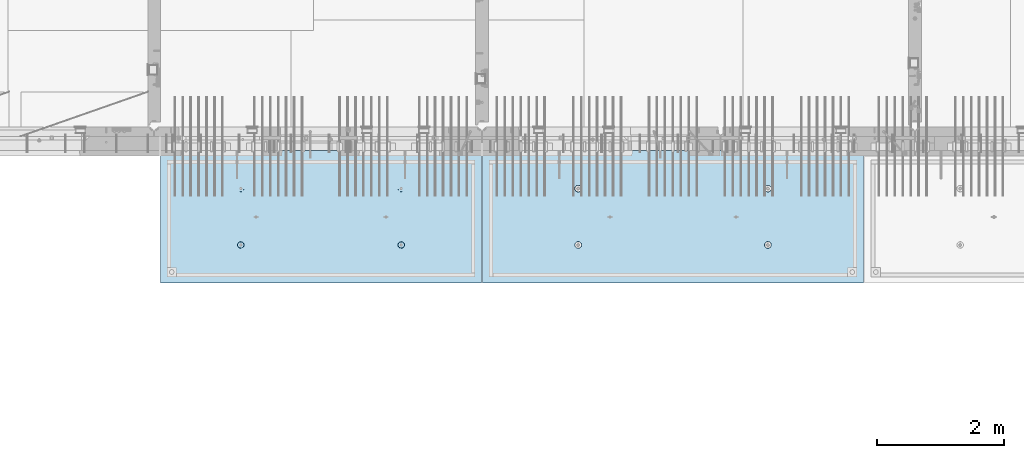
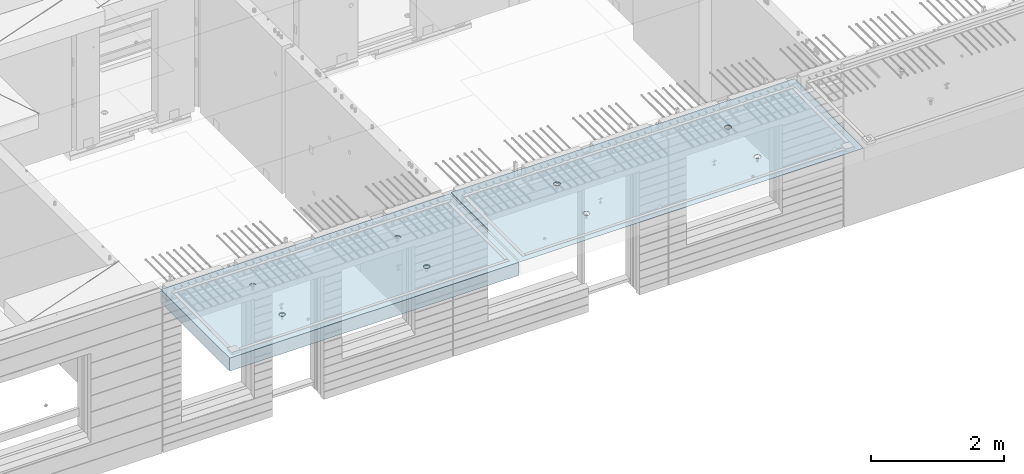
# One storey, part 200 of 352: 2 slabs, 2 elements without a shape of their own.
"""IFC2X3 building model written with IfcOpenShell, lengths in millimetres."""

from ifc_helpers import new_model, si_unit, frame, origin_with_axes, place, context, subcontext, project, spatial, faceted_brep, material, type_object, element, aggregate, save


model = new_model("IFC2X3")

# Units and contexts
model_context = context("Model", 3, precision=1e-05, world=origin_with_axes())
body_context = subcontext(model_context, "Body", "Model", "MODEL_VIEW")
ifc_project = project(units=[si_unit("LENGTHUNIT", "METRE", prefix="MILLI"), si_unit("AREAUNIT", "SQUARE_METRE"), si_unit("VOLUMEUNIT", "CUBIC_METRE"), si_unit("MASSUNIT", "GRAM", prefix="KILO"), si_unit("TIMEUNIT", "SECOND"), si_unit("PLANEANGLEUNIT", "RADIAN"), si_unit("SOLIDANGLEUNIT", "STERADIAN"), si_unit("THERMODYNAMICTEMPERATUREUNIT", "DEGREE_CELSIUS"), si_unit("LUMINOUSINTENSITYUNIT", "LUMEN")], contexts=[model_context])

# Site, building, storey
site_placement = place(None, origin_with_axes())
site = spatial("IfcSite", under=ifc_project, at=site_placement, CompositionType="ELEMENT")
building_placement = place(site_placement, origin_with_axes())
building = spatial("IfcBuilding", under=site, at=building_placement, CompositionType="ELEMENT")
storey_placement = place(building_placement, origin_with_axes())
storey = spatial("IfcBuildingStorey", under=building, at=storey_placement, Name="6", CompositionType="ELEMENT", Elevation=0.0)

# Assembly, slab
assembly_1_placement = place(storey_placement, origin_with_axes())
assembly_1 = element("IfcElementAssembly", 1, at=assembly_1_placement, inside=storey, AssemblyPlace="NOTDEFINED", PredefinedType="REINFORCEMENT_UNIT")
ifc_material = material(Name="CONCRETE/C35/45")
slab_type_1 = type_object("IfcSlabType", PredefinedType="NOTDEFINED")
slab_1_placement = place(assembly_1_placement, frame((27799.9998568133, 7629.99655735226, 99720.0), z_axis=(-1.11800000013248e-06, -0.999999999999375, 0.0), x_axis=(-0.999999999999093, 1.34699999998405e-06, 0.0)))
slab_1 = element("IfcSlab", 2, at=slab_1_placement, type_object=slab_type_1, material=ifc_material, PredefinedType="FLOOR", context=body_context, shape_type="Brep", body=[
    faceted_brep([(4430.38332613536, -4.08995228011918, 616.123557002266), (4431.90609271965, 10.0, 615.628782084005), (4439.08875686405, 10.0, 629.725594302773), (4437.8062304225, -3.95053914321761, 630.657402050439), (4450.27603094506, 10.0, 640.912894136913), (4449.35160622641, -3.83996043598745, 642.185252526786), (4464.3728266293, 10.0, 648.095590732159), (4463.88931892896, -3.76899254079035, 649.583668593681), (4479.99925133704, 10.0, 650.570591700976), (4479.99924953932, -3.74454363348195, 652.132471659324), (4495.6256817422, 10.0, 648.095626704194), (4496.1091860045, -3.76899218543258, 649.583705640341), (4509.72249396096, 10.0, 640.912962559792), (4510.64691570547, -3.83995975981816, 642.185323015524), (4520.9097937951, 10.0, 629.725688478787), (4522.19231800603, -3.95053821212787, 630.657499116635), (4528.09249039035, 10.0, 615.628892794549), (4529.6152557173, -4.08995118488383, 616.123671179757), (4530.56749135917, 10.0, 600.002468086805), (4532.18619485158, -4.24459073322942, 600.002469949934), (4528.09252636238, 10.0, 584.37603768165), (4529.64872932557, -4.39933455047139, 583.870398667863), (4520.90986221798, 10.0, 570.279225462882), (4522.24649000407, -4.53902051890327, 569.308110882728), (4509.72258813697, 10.0, 559.091925628744), (4510.70111430095, -4.6499364652409, 557.745103167879), (4495.62579245274, 10.0, 551.909229033497), (4496.142736776, -4.72117719323433, 550.318244231095), (4479.99936774499, 10.0, 549.43422806468), (4479.99936967367, -4.74573031402542, 547.758576892632), (4464.37293733984, 10.0, 551.909193061462), (4463.8559966665, -4.72117755009094, 550.318207030491), (4450.27612512107, 10.0, 559.091857205865), (4449.29760201216, -4.64993714379671, 557.745032430054), (4439.08882528693, 10.0, 570.279131286869), (4437.75219965053, -4.53902145239408, 569.308013567449), (4431.90612869169, 10.0, 584.375926971106), (4430.34992677396, -4.39933564719104, 583.87028433643), (4429.43112772287, 10.0, 600.002351678851), (4427.81242409951, -4.24459188559558, 600.002349815723), (0.0, 10.0, 0.0), (0.0, -10.0, 0.0), (0.000819232023786753, 10.0, 2085.00366210937), (5980.0, 10.0, -2.4019755073823e-09), (5980.0, -10.0, -2.4019755073823e-09), (5980.0009765625, 10.0, 2085.00366210937), (1450.3499233011, -4.39936856077111, 583.866853138679), (1451.90612877595, 10.0, 584.37249692914), (1449.43112780714, 10.0, 599.998921636884), (1447.81242044485, -4.24462478808709, 599.998919773752), (1457.75219670802, -4.53905437597132, 569.304581326389), (1459.0888253712, 10.0, 570.275701244902), (1469.29759989681, -4.64997007531929, 557.741599360567), (1470.27612520534, 10.0, 559.088427163899), (1483.85599559418, -4.7212104867067, 550.31477342891), (1484.3729374241, 10.0, 551.905763019495), (1499.99936975794, -4.74576325241651, 547.755143107666), (1499.99936782926, 10.0, 549.430798022713), (1516.14273801685, -4.72121012986463, 550.314810629518), (1515.62579253701, 10.0, 551.905798991532), (1530.70111658485, -4.64996939677803, 557.741670098397), (1529.72258822124, 10.0, 559.088495586778), (1542.24649311513, -4.53905344249506, 569.304678641675), (1540.90986230225, 10.0, 570.275795420916), (1549.64873296696, -4.39936746405147, 583.866967470121), (1548.09252644665, 10.0, 584.372607639683), (1552.18619867476, -4.24462363570638, 599.999039907971), (1550.56749144343, 10.0, 599.999038044839), (1549.61525935629, -4.08998407628678, 616.120242292795), (1548.09249047462, 10.0, 615.625462752582), (1542.19232111321, -3.95057109353365, 630.654071270945), (1540.90979387937, 10.0, 629.72225843682), (1530.64691798548, -3.83999263332225, 642.181895995745), (1529.72249404523, 10.0, 640.909532517825), (1516.10918724295, -3.76902505384351, 649.580279150618), (1515.62568182647, 10.0, 648.092196662228), (1499.99924962358, -3.7445765001321, 652.129045352205), (1499.9992514213, 10.0, 650.56716165901), (1483.88931785903, -3.76902540921583, 649.580242103954), (1484.37282671356, 10.0, 648.092160690191), (1469.35160411493, -3.83999330949155, 642.181825507), (1470.27603102933, 10.0, 640.909464094946), (1457.80622748385, -3.9505720246525, 630.653974204743), (1459.08875694832, 10.0, 629.722164260806), (1450.3833226649, -4.08998517153668, 616.120128115297), (1451.90609280392, 10.0, 615.625352042039), (1450.18528173966, 4.08930273250735, 1468.81238974452), (1450.82407776805, 10.0, 1469.01994796889), (1448.29345879993, 10.0, 1484.99752828805), (1447.63943102495, 4.24455558012414, 1484.99752753526), (1457.61190709188, 3.94915737991687, 1454.20221107617), (1458.16818327555, 10.0, 1454.60637035917), (1469.19529226424, 3.83787679090165, 1442.60118929624), (1469.60688310596, 10.0, 1443.16769686061), (1483.80158206606, 3.76640201332339, 1435.14993064656), (1484.02047762178, 10.0, 1435.82362453319), (1499.99806458492, 3.74176847410854, 1432.58187967207), (1499.99806376637, 10.0, 1433.29304234547), (1516.19454117951, 3.76640237134416, 1435.14996796955), (1515.97564408552, 10.0, 1435.82366131359), (1530.80081379559, 3.8378774716839, 1442.60126026678), (1530.38922169525, 10.0, 1443.16776682109), (1542.38417222175, 3.94915831647813, 1454.2023087116), (1541.82789519381, 10.0, 1454.6064666515), (1549.8107639085, 4.08930383282132, 1468.81250445209), (1549.17196752123, 10.0, 1469.02006116732), (1552.35657735256, 4.24455673628836, 1484.9976480647), (1551.70254970896, 10.0, 1484.99764731191), (1549.77718017658, 4.39970502781216, 1501.17188586406), (1549.17193074083, 10.0, 1500.97522763107), (1542.32982200517, 4.53957665037888, 1515.75352812725), (1541.82782523334, 10.0, 1515.38880524079), (1530.74643689407, 4.65051889081951, 1527.31927700612), (1530.38912540293, 10.0, 1526.82747873935), (1516.16088003051, 4.72171993891243, 1534.74199930817), (1515.9755308871, 10.0, 1534.17155106677), (1499.99794405534, 4.74624892331485, 1537.2991504223), (1499.99794474251, 10.0, 1536.70213325449), (1483.83501395426, 4.72171958237595, 1534.74196213963), (1484.02036442336, 10.0, 1534.17151428637), (1469.24947414505, 4.65051821242378, 1527.31920628548), (1469.60678681363, 10.0, 1526.82740877888), (1457.66611561777, 4.53957571620413, 1515.75343074172), (1458.16811331507, 10.0, 1515.38870894846), (1450.21879098044, 4.39970392896794, 1501.17177131094), (1450.82404098765, 10.0, 1500.97511443265), (4495.97553080284, 10.0, 1534.17498110874), (4496.16087879206, 4.72175280732336, 1534.74542579789), (4479.99794397108, 4.746281789965, 1537.30257672942), (4479.99794465824, 10.0, 1536.70556329646), (4510.38912531866, 10.0, 1526.83090878132), (4510.74643461406, 4.65055176430906, 1527.3227040259), (4521.82782514907, 10.0, 1515.39223528276), (4522.32981889799, 4.53960953179921, 1515.75695597294), (4529.17193065656, 10.0, 1500.97865767303), (4529.77717653759, 4.39973791921511, 1501.17531475103), (4531.70254962468, 10.0, 1485.00107735388), (4532.35657352936, 4.24458963877987, 1485.00107810666), (4529.17196743696, 10.0, 1469.02349120928), (4529.8107602671, 4.08933674640139, 1468.81593564983), (4521.82789510954, 10.0, 1454.60989669347), (4522.38416911069, 3.94919124005537, 1454.20574095265), (4510.38922161098, 10.0, 1443.17119686305), (4510.8008115117, 3.83791040322103, 1442.60469333626), (4495.97564400126, 10.0, 1435.82709135556), (4496.19453993865, 3.76643530797446, 1435.15340157113), (4479.99806368211, 10.0, 1433.29647238744), (4479.99806450065, 3.74180141248507, 1432.58531345704), (4464.02047753751, 10.0, 1435.82705457516), (4463.80158313838, 3.76643494995369, 1435.15336424814), (4449.60688302169, 10.0, 1443.17112690258), (4449.19529437959, 3.83790972242423, 1442.60462236572), (4438.16818319128, 10.0, 1454.60980040114), (4437.61191003439, 3.94919030349411, 1454.20564331723), (4430.82407768378, 10.0, 1469.02337801086), (4430.18528521251, 4.08933564607287, 1468.81582094227), (4437.66611855642, 4.53960859763902, 1515.75685858742), (4449.24947625653, 4.65055108592787, 1527.32263330526), (4463.83501502419, 4.72175245078688, 1534.74538862936), (4427.63943467959, 4.24458848261565, 1485.00095757723), (4430.2187944509, 4.39973682038544, 1501.17520019791), (4464.02036433909, 10.0, 1534.17494432834), (4449.60678672936, 10.0, 1526.83083882084), (4438.1681132308, 10.0, 1515.39213899043), (4430.82404090338, 10.0, 1500.97854447461), (4428.29345871566, 10.0, 1485.00095833002)], [[[0, 1, 2, 3]], [[3, 2, 4, 5]], [[5, 4, 6, 7]], [[7, 6, 8, 9]], [[10, 11, 9, 8]], [[12, 13, 11, 10]], [[14, 15, 13, 12]], [[16, 17, 15, 14]], [[18, 19, 17, 16]], [[20, 21, 19, 18]], [[22, 23, 21, 20]], [[24, 25, 23, 22]], [[26, 27, 25, 24]], [[27, 26, 28, 29]], [[29, 28, 30, 31]], [[31, 30, 32, 33]], [[33, 32, 34, 35]], [[35, 34, 36, 37]], [[37, 36, 38, 39]], [[39, 38, 1, 0]], [[40, 41, 42]], [[40, 43, 44, 41]], [[43, 45, 44]], [[46, 47, 48, 49]], [[50, 51, 47, 46]], [[52, 53, 51, 50]], [[54, 55, 53, 52]], [[56, 57, 55, 54]], [[58, 59, 57, 56]], [[59, 58, 60, 61]], [[61, 60, 62, 63]], [[63, 62, 64, 65]], [[65, 64, 66, 67]], [[67, 66, 68, 69]], [[69, 68, 70, 71]], [[71, 70, 72, 73]], [[73, 72, 74, 75]], [[75, 74, 76, 77]], [[78, 79, 77, 76]], [[80, 81, 79, 78]], [[82, 83, 81, 80]], [[84, 85, 83, 82]], [[49, 48, 85, 84]], [[86, 87, 88, 89]], [[90, 91, 87, 86]], [[92, 93, 91, 90]], [[94, 95, 93, 92]], [[96, 97, 95, 94]], [[98, 99, 97, 96]], [[100, 101, 99, 98]], [[101, 100, 102, 103]], [[103, 102, 104, 105]], [[105, 104, 106, 107]], [[107, 106, 108, 109]], [[109, 108, 110, 111]], [[111, 110, 112, 113]], [[113, 112, 114, 115]], [[115, 114, 116, 117]], [[117, 116, 118, 119]], [[120, 121, 119, 118]], [[122, 123, 121, 120]], [[124, 125, 123, 122]], [[89, 88, 125, 124]], [[126, 127, 128, 129]], [[130, 131, 127, 126]], [[132, 133, 131, 130]], [[134, 135, 133, 132]], [[136, 137, 135, 134]], [[138, 139, 137, 136]], [[140, 141, 139, 138]], [[142, 143, 141, 140]], [[143, 142, 144, 145]], [[145, 144, 146, 147]], [[147, 146, 148, 149]], [[149, 148, 150, 151]], [[151, 150, 152, 153]], [[153, 152, 154, 155]], [[41, 44, 45, 42], [3, 5, 7, 9, 11, 13, 15, 17, 19, 21, 23, 25, 27, 29, 31, 33, 35, 37, 39, 0], [156, 157, 158, 128, 127, 131, 133, 135, 137, 139, 141, 143, 145, 147, 149, 151, 153, 155, 159, 160], [122, 120, 118, 116, 114, 112, 110, 108, 106, 104, 102, 100, 98, 96, 94, 92, 90, 86, 89, 124], [82, 80, 78, 76, 74, 72, 70, 68, 66, 64, 62, 60, 58, 56, 54, 52, 50, 46, 49, 84]], [[129, 128, 158, 161]], [[157, 162, 161, 158]], [[156, 163, 162, 157]], [[160, 164, 163, 156]], [[159, 165, 164, 160]], [[155, 154, 165, 159]], [[43, 40, 42, 45], [34, 32, 30, 28, 26, 24, 22, 20, 18, 16, 14, 12, 10, 8, 6, 4, 2, 1, 38, 36], [152, 150, 148, 146, 144, 142, 140, 138, 136, 134, 132, 130, 126, 129, 161, 162, 163, 164, 165, 154], [91, 93, 95, 97, 99, 101, 103, 105, 107, 109, 111, 113, 115, 117, 119, 121, 123, 125, 88, 87], [51, 53, 55, 57, 59, 61, 63, 65, 67, 69, 71, 73, 75, 77, 79, 81, 83, 85, 48, 47]]]),
])
aggregate(assembly_1, [slab_1])

assembly_2_placement = place(storey_placement, origin_with_axes())
assembly_2 = element("IfcElementAssembly", 3, at=assembly_2_placement, inside=storey, AssemblyPlace="NOTDEFINED", PredefinedType="REINFORCEMENT_UNIT")
slab_type_2 = type_object("IfcSlabType", PredefinedType="NOTDEFINED")
slab_2_placement = place(assembly_2_placement, frame((21799.9998568133, 7629.99655735226, 99590.0), z_axis=(-1.11800000013248e-06, -0.999999999999375, 0.0), x_axis=(-0.999999999999093, 1.34699999998405e-06, 0.0)))
slab_2 = element("IfcSlab", 4, at=slab_2_placement, type_object=slab_type_2, material=ifc_material, PredefinedType="FLOOR", context=body_context, shape_type="Brep", body=[
    faceted_brep([(1275.44980856604, -115.0, 552.444777751491), (1289.3882117606, -115.0, 559.546772887367), (1300.44978375459, -115.0, 570.608375101608), (1307.55174081072, -115.0, 584.54679769877), (1309.9988938901, -115.0, 599.997650760343), (1307.551698599, -115.0, 615.448497136235), (1300.44970346313, -115.0, 629.3869003308), (1289.38810124889, -115.0, 640.448472324786), (1275.44967865172, -115.0, 647.550429380917), (1259.99882559015, -115.0, 649.997582460297), (1244.54797921425, -115.0, 647.550387169195), (1230.60957601969, -115.0, 640.44839203332), (1219.54800402571, -115.0, 629.386789819078), (1212.44604696957, -115.0, 615.448367221916), (1209.9988938902, -115.0, 599.997514160343), (1212.4460891813, -115.0, 584.546667784451), (1219.54808431717, -115.0, 570.608264589886), (1230.60968653141, -115.0, 559.546692595902), (1244.54810912857, -115.0, 552.444735539769), (1259.99896219015, -115.0, 549.99758246039), (1219.08841602657, -120.0, 570.274295068632), (1211.90571640051, -120.0, 584.371089208588), (1230.27571826597, -120.0, 559.087023392896), (1244.37253202901, -120.0, 551.904362279308), (1259.99896296629, -120.0, 549.429400642209), (1275.6253871419, -120.0, 551.904404970708), (1289.72218128186, -120.0, 559.087104596764), (1300.9094529576, -120.0, 570.274406836168), (1308.09211407118, -120.0, 584.371220599207), (1310.56707570828, -120.0, 599.99765153648), (1308.09207137979, -120.0, 615.624075712098), (1300.90937175373, -120.0, 629.720869852056), (1289.72206951433, -120.0, 640.90814152779), (1275.62525575129, -120.0, 648.090802641378), (1259.99882481401, -120.0, 650.565764278478), (1244.37240063839, -120.0, 648.090759949978), (1230.27560649844, -120.0, 640.908060323922), (1219.0883348227, -120.0, 629.72075808452), (1211.90567370912, -120.0, 615.623944321479), (1209.43071207202, -120.0, 599.997513384206), (0.000328360383718973, -120.0, 2085.00366210938), (5040.00048828125, -120.0, 2085.00366210938), (5040.00048828125, 120.0, 2085.00366210938), (0.000328360383718973, 120.0, 2085.00366210938), (5040.0, -120.0, -2.18278728425503e-09), (5040.0, 120.0, -2.18278728425503e-09), (-7.27595761418343e-12, -120.0, -9.09494701772928e-13), (-7.27595761418343e-12, 120.0, -9.09494701772928e-13), (1275.44859965604, -105.0, 1437.44477775066), (1289.38700285061, -105.0, 1444.54677288654), (1300.44857484459, -105.0, 1455.60837510078), (1307.55053190072, -105.0, 1469.54679769794), (1309.9976849801, -105.0, 1484.99765075952), (1307.550489689, -105.0, 1500.44849713541), (1300.44849455313, -105.0, 1514.38690032997), (1289.38689233888, -105.0, 1525.44847232396), (1275.44846974172, -105.0, 1532.55042938009), (1259.99761668015, -105.0, 1534.99758245947), (1244.54677030425, -105.0, 1532.55038716837), (1230.60836710969, -105.0, 1525.44839203249), (1219.5467951157, -105.0, 1514.38678981825), (1212.44483805958, -105.0, 1500.44836722109), (1209.99768498019, -105.0, 1484.99751415952), (1212.44488027129, -105.0, 1469.54666778362), (1219.54687540717, -105.0, 1455.60826458906), (1230.60847762142, -105.0, 1444.54669259508), (1244.54690021857, -105.0, 1437.44473553894), (1259.99775328015, -105.0, 1434.99758245956), (1210.82376192895, -120.0, 1469.01993205604), (1208.29313952565, -120.0, 1484.99751183111), (1218.16787053537, -120.0, 1454.60635602529), (1229.60657282509, -120.0, 1443.16768498606), (1244.02016891989, -120.0, 1435.82361575756), (1259.99775560856, -120.0, 1433.29303700502), (1275.97533538363, -120.0, 1435.82365940832), (1290.38891141437, -120.0, 1443.16776801474), (1301.82758245361, -120.0, 1454.60647030446), (1309.17165168211, -120.0, 1469.02006639925), (1311.70223043464, -120.0, 1484.99765308793), (1309.17160803135, -120.0, 1500.975232863), (1301.82749942493, -120.0, 1515.38880889374), (1290.3887971352, -120.0, 1526.82747993297), (1275.97520104041, -120.0, 1534.17154916147), (1259.99761435174, -120.0, 1536.70212791401), (1244.02003457667, -120.0, 1534.17150551072), (1229.60645854592, -120.0, 1526.8273969043), (1218.16778750669, -120.0, 1515.38869461457), (1210.82371827819, -120.0, 1500.97509851978), (3795.4485995714, -105.0, 1437.44822013263), (3809.38700276596, -105.0, 1444.55021526851), (3820.44857475995, -105.0, 1455.61181748275), (3827.55053181608, -105.0, 1469.55024007991), (3829.99768489545, -105.0, 1485.00109314148), (3827.55048960436, -105.0, 1500.45193951738), (3820.44849446848, -105.0, 1514.39034271194), (3809.38689225424, -105.0, 1525.45191470593), (3795.44846965708, -105.0, 1532.55387176206), (3779.9976165955, -105.0, 1535.00102484144), (3764.54677021961, -105.0, 1532.55382955034), (3750.60836702505, -105.0, 1525.45183441446), (3739.54679503106, -105.0, 1514.39023220022), (3732.44483797493, -105.0, 1500.45180960306), (3729.99768489555, -105.0, 1485.00095654148), (3732.44488018665, -105.0, 1469.55011016559), (3739.54687532252, -105.0, 1455.61170697103), (3750.60847753677, -105.0, 1444.55013497704), (3764.54690013393, -105.0, 1437.44817792091), (3779.9977531955, -105.0, 1435.00102484153), (3730.82376184431, -120.0, 1469.023374438), (3728.293139441, -120.0, 1485.00095421308), (3738.16787045072, -120.0, 1454.60979840726), (3749.60657274045, -120.0, 1443.17112736803), (3764.02016883524, -120.0, 1435.82705813953), (3779.99775552391, -120.0, 1433.29647938699), (3795.97533529898, -120.0, 1435.82710179029), (3810.38891132972, -120.0, 1443.1712103967), (3821.82758236896, -120.0, 1454.60991268643), (3829.17165159746, -120.0, 1469.02350878122), (3831.70223035, -120.0, 1485.00109546989), (3829.1716079467, -120.0, 1500.97867524497), (3821.82749934028, -120.0, 1515.39225127571), (3810.38879705056, -120.0, 1526.83092231494), (3795.97520095576, -120.0, 1534.17499154344), (3779.99761426709, -120.0, 1536.70557029598), (3764.02003449202, -120.0, 1534.17494789268), (3749.60645846128, -120.0, 1526.83083928627), (3738.16778742204, -120.0, 1515.39213699654), (3730.82371819355, -120.0, 1500.97854090175), (3795.4498084814, -115.0, 552.448220133458), (3809.38821167596, -115.0, 559.550215269334), (3820.44978366995, -115.0, 570.611817483575), (3827.55174072608, -115.0, 584.550240080738), (3829.99889380546, -115.0, 600.00109314231), (3827.55169851435, -115.0, 615.451939518203), (3820.44970337848, -115.0, 629.390342712767), (3809.38810116424, -115.0, 640.451914706753), (3795.44967856708, -115.0, 647.553871762884), (3779.9988255055, -115.0, 650.001024842264), (3764.54797912961, -115.0, 647.553829551163), (3750.60957593505, -115.0, 640.451834415288), (3739.54800394106, -115.0, 629.390232201046), (3732.44604688493, -115.0, 615.451809603883), (3729.99889380555, -115.0, 600.000956542311), (3732.44608909665, -115.0, 584.550110166418), (3739.54808423252, -115.0, 570.611706971854), (3750.60968644677, -115.0, 559.550134977869), (3764.54810904393, -115.0, 552.448177921737), (3779.9989621055, -115.0, 550.001024842357), (3731.90571631587, -120.0, 584.374531590555), (3729.43071198737, -120.0, 600.000955766174), (3739.08841594193, -120.0, 570.277737450599), (3750.27571818133, -120.0, 559.090465774863), (3764.37253194437, -120.0, 551.907804661275), (3779.99896288164, -120.0, 549.432843024176), (3795.62538705726, -120.0, 551.907847352675), (3809.72218119721, -120.0, 559.090546978732), (3820.90945287295, -120.0, 570.277849218135), (3828.09211398654, -120.0, 584.374662981175), (3830.56707562364, -120.0, 600.001093918447), (3828.09207129514, -120.0, 615.627518094066), (3820.90937166908, -120.0, 629.724312234023), (3809.72206942968, -120.0, 640.911583909758), (3795.62525566664, -120.0, 648.094245023345), (3779.99882472937, -120.0, 650.569206660445), (3764.37240055375, -120.0, 648.094202331945), (3750.27560641379, -120.0, 640.911502705889), (3739.08833473806, -120.0, 629.724200466487), (3731.90567362447, -120.0, 615.627386703446)], [[[0, 1, 2, 3, 4, 5, 6, 7, 8, 9, 10, 11, 12, 13, 14, 15, 16, 17, 18, 19]], [[20, 16, 15, 21]], [[22, 17, 16, 20]], [[23, 18, 17, 22]], [[24, 19, 18, 23]], [[25, 0, 19, 24]], [[26, 1, 0, 25]], [[27, 2, 1, 26]], [[28, 3, 2, 27]], [[29, 4, 3, 28]], [[30, 5, 4, 29]], [[31, 6, 5, 30]], [[32, 7, 6, 31]], [[33, 8, 7, 32]], [[34, 9, 8, 33]], [[35, 10, 9, 34]], [[36, 11, 10, 35]], [[37, 12, 11, 36]], [[38, 13, 12, 37]], [[39, 14, 13, 38]], [[21, 15, 14, 39]], [[40, 41, 42, 43]], [[41, 44, 45, 42]], [[44, 46, 47, 45]], [[42, 45, 47, 43]], [[46, 40, 43, 47]], [[48, 49, 50, 51, 52, 53, 54, 55, 56, 57, 58, 59, 60, 61, 62, 63, 64, 65, 66, 67]], [[68, 63, 62, 69]], [[70, 64, 63, 68]], [[71, 65, 64, 70]], [[72, 66, 65, 71]], [[73, 67, 66, 72]], [[74, 48, 67, 73]], [[75, 49, 48, 74]], [[76, 50, 49, 75]], [[77, 51, 50, 76]], [[78, 52, 51, 77]], [[79, 53, 52, 78]], [[80, 54, 53, 79]], [[81, 55, 54, 80]], [[82, 56, 55, 81]], [[83, 57, 56, 82]], [[84, 58, 57, 83]], [[85, 59, 58, 84]], [[86, 60, 59, 85]], [[87, 61, 60, 86]], [[69, 62, 61, 87]], [[88, 89, 90, 91, 92, 93, 94, 95, 96, 97, 98, 99, 100, 101, 102, 103, 104, 105, 106, 107]], [[108, 103, 102, 109]], [[110, 104, 103, 108]], [[111, 105, 104, 110]], [[112, 106, 105, 111]], [[113, 107, 106, 112]], [[114, 88, 107, 113]], [[115, 89, 88, 114]], [[116, 90, 89, 115]], [[117, 91, 90, 116]], [[118, 92, 91, 117]], [[119, 93, 92, 118]], [[120, 94, 93, 119]], [[121, 95, 94, 120]], [[122, 96, 95, 121]], [[123, 97, 96, 122]], [[124, 98, 97, 123]], [[125, 99, 98, 124]], [[126, 100, 99, 125]], [[127, 101, 100, 126]], [[109, 102, 101, 127]], [[128, 129, 130, 131, 132, 133, 134, 135, 136, 137, 138, 139, 140, 141, 142, 143, 144, 145, 146, 147]], [[148, 143, 142, 149]], [[150, 144, 143, 148]], [[151, 145, 144, 150]], [[152, 146, 145, 151]], [[153, 147, 146, 152]], [[154, 128, 147, 153]], [[155, 129, 128, 154]], [[156, 130, 129, 155]], [[157, 131, 130, 156]], [[158, 132, 131, 157]], [[159, 133, 132, 158]], [[160, 134, 133, 159]], [[161, 135, 134, 160]], [[162, 136, 135, 161]], [[163, 137, 136, 162]], [[164, 138, 137, 163]], [[165, 139, 138, 164]], [[166, 140, 139, 165]], [[167, 141, 140, 166]], [[149, 142, 141, 167]], [[44, 41, 40, 46], [37, 36, 35, 34, 33, 32, 31, 30, 29, 28, 27, 26, 25, 24, 23, 22, 20, 21, 39, 38], [166, 165, 164, 163, 162, 161, 160, 159, 158, 157, 156, 155, 154, 153, 152, 151, 150, 148, 149, 167], [126, 125, 124, 123, 122, 121, 120, 119, 118, 117, 116, 115, 114, 113, 112, 111, 110, 108, 109, 127], [86, 85, 84, 83, 82, 81, 80, 79, 78, 77, 76, 75, 74, 73, 72, 71, 70, 68, 69, 87]]]),
])
aggregate(assembly_2, [slab_2])

save(model, "model.ifc")
